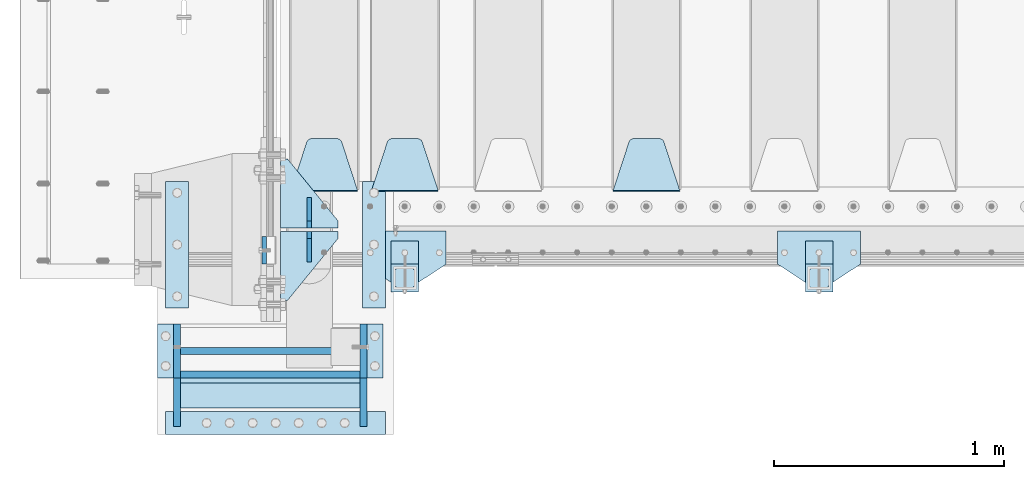
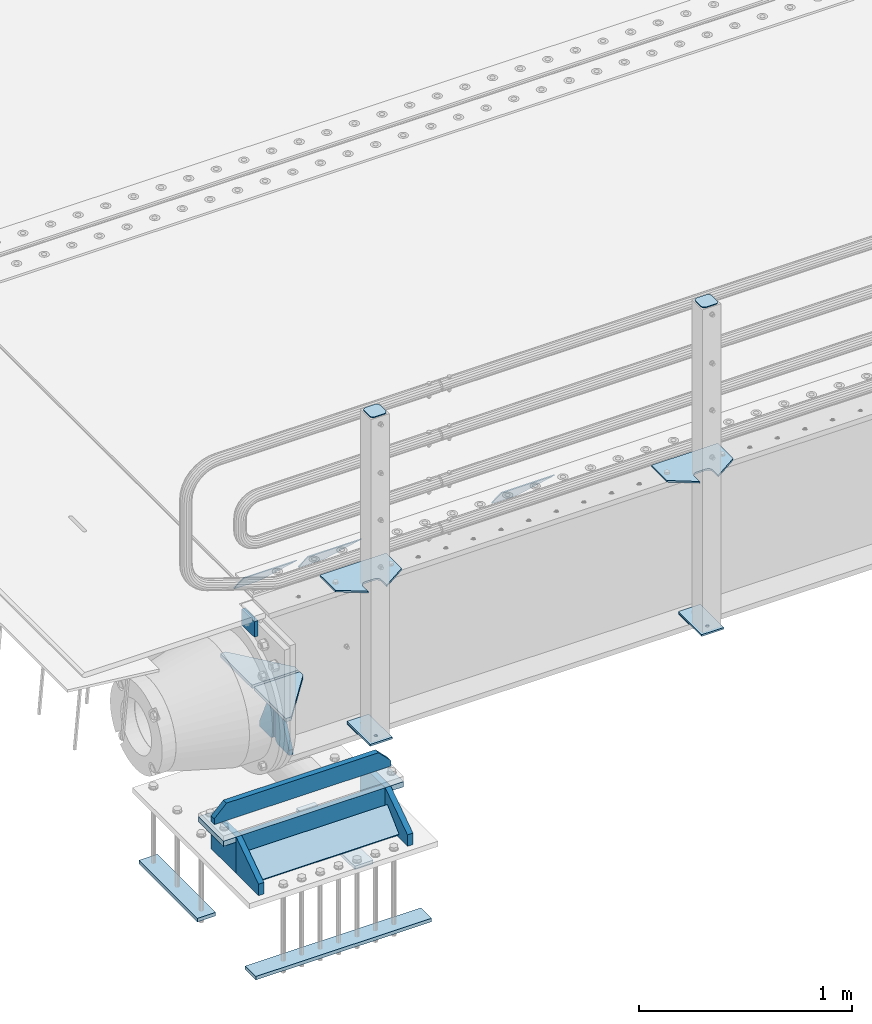
# One storey, part 202 of 257: 28 plates.
"""IFC2X3 building model written with IfcOpenShell, lengths in millimetres."""

from ifc_helpers import new_model, si_unit, frame, origin_with_axes, place, context, subcontext, project, spatial, faceted_brep, material, type_object, element, save


model = new_model("IFC2X3")

# Units and contexts
model_context = context("Model", 3, precision=1e-05, world=origin_with_axes())
body_context = subcontext(model_context, "Body", "Model", "MODEL_VIEW")
ifc_project = project(units=[si_unit("LENGTHUNIT", "METRE", prefix="MILLI"), si_unit("AREAUNIT", "SQUARE_METRE"), si_unit("VOLUMEUNIT", "CUBIC_METRE"), si_unit("MASSUNIT", "GRAM", prefix="KILO"), si_unit("TIMEUNIT", "SECOND"), si_unit("PLANEANGLEUNIT", "RADIAN"), si_unit("SOLIDANGLEUNIT", "STERADIAN"), si_unit("THERMODYNAMICTEMPERATUREUNIT", "DEGREE_CELSIUS"), si_unit("LUMINOUSINTENSITYUNIT", "LUMEN")], contexts=[model_context])

# Site, building, storey
site_placement = place(None, origin_with_axes())
site = spatial("IfcSite", under=ifc_project, at=site_placement, CompositionType="ELEMENT")
building_placement = place(site_placement, origin_with_axes())
building = spatial("IfcBuilding", under=site, at=building_placement, Name="Standard", CompositionType="ELEMENT")
storey_placement = place(building_placement, origin_with_axes())
storey = spatial("IfcBuildingStorey", under=building, at=storey_placement, Name="Undefined", CompositionType="ELEMENT", Elevation=0.0)

# Plates
ifc_material_1 = material(Name="STEEL/S355N")
plate_type_1 = type_object("IfcPlateType", PredefinedType="NOTDEFINED")
plate_1_placement = place(storey_placement, frame((42390.0, -29.9995540187374, -106.000123865875), z_axis=(0.0, -0.999999999987744, -4.95099999993769e-06), x_axis=(0.0, -4.95099999998473e-06, 0.999999999987744)))
element("IfcPlate", 1, at=plate_1_placement, inside=storey, type_object=plate_type_1, material=ifc_material_1, context=body_context, shape_type="Brep", body=[
    faceted_brep([(0.0, -10.0, 0.0), (5.7072624315424e-07, -10.0, 120.0), (5.7072624315424e-07, 10.0, 120.0), (0.0, 10.0, 0.0), (90.0, -10.0, 120.0), (90.0, 10.0, 120.0), (90.0, -10.0, 1.09139364212751e-11), (90.0, 10.0, 1.09139364212751e-11)], [[[0, 1, 2, 3]], [[1, 4, 5, 2]], [[4, 6, 7, 5]], [[6, 0, 3, 7]], [[5, 7, 3, 2]], [[6, 4, 1, 0]]]),
])
plate_type_2 = type_object("IfcPlateType", PredefinedType="NOTDEFINED")
plate_2_placement = place(storey_placement, frame((44195.0, 168.232233047034, -1.76776695296758), z_axis=(0.0, 0.707106781186547, -0.707106781186548), x_axis=(-1.0, 0.0, 0.0)))
element("IfcPlate", 2, at=plate_2_placement, inside=storey, type_object=plate_type_2, material=ifc_material_1, context=body_context, shape_type="Brep", body=[
    faceted_brep([(0.0, -2.5, 0.0), (69.345504679477, -2.50000000000091, 300.17173142483), (69.345504679477, 2.5, 300.171731424831), (0.0, 2.5, 0.0), (70.927406119954, -2.50000000000091, 304.8974424154), (70.927406119954, 2.5, 304.8974424154), (73.3818627772271, -2.50000000000091, 309.234538108527), (73.3818627772271, 2.49999999999909, 309.234538108527), (76.6187032999587, -2.5, 313.023683126103), (76.6187032999587, 2.5, 313.023683126103), (80.5190132705029, -2.5, 316.125672595372), (80.5190132705029, 2.5, 316.125672595371), (84.9395038596849, -2.5, 318.426546230476), (84.9395038596849, 2.5, 318.426546230477), (89.7177759439219, -2.5, 319.841774983275), (89.7177759439219, 2.5, 319.841774983275), (94.6782862926484, -2.5, 320.319366455079), (94.6782862926484, 2.5, 320.319366455079), (195.321713707352, -2.5, 320.319366455079), (195.321713707352, 2.5, 320.319366455079), (200.282224056078, -2.5, 319.841774983275), (200.282224056078, 2.49999999999909, 319.841774983275), (205.060496140315, -2.5, 318.426546230476), (205.060496140315, 2.49999999999909, 318.426546230475), (209.480986729497, -2.5, 316.125672595371), (209.480986729497, 2.5, 316.125672595371), (213.381296700041, -2.50000000000091, 313.023683126102), (213.381296700041, 2.5, 313.023683126103), (216.618137222766, -2.50000000000091, 309.234538108527), (216.618137222766, 2.5, 309.234538108527), (219.072593880039, -2.5, 304.897442415399), (219.072593880039, 2.5, 304.897442415399), (220.654495320523, -2.50000000000091, 300.17173142483), (220.654495320523, 2.5, 300.171731424831), (290.0, -2.50000000000091, 0.0), (290.0, 2.5, 9.09494701772928e-13)], [[[0, 1, 2, 3]], [[1, 4, 5, 2]], [[4, 6, 7, 5]], [[6, 8, 9, 7]], [[8, 10, 11, 9]], [[10, 12, 13, 11]], [[12, 14, 15, 13]], [[14, 16, 17, 15]], [[16, 18, 19, 17]], [[18, 20, 21, 19]], [[20, 22, 23, 21]], [[22, 24, 25, 23]], [[24, 26, 27, 25]], [[26, 28, 29, 27]], [[28, 30, 31, 29]], [[30, 32, 33, 31]], [[32, 34, 35, 33]], [[34, 0, 3, 35]], [[5, 7, 9, 11, 13, 15, 17, 19, 21, 23, 25, 27, 29, 31, 33, 35, 3, 2]], [[34, 32, 30, 28, 26, 24, 22, 20, 18, 16, 14, 12, 10, 8, 6, 4, 1, 0]]]),
])
plate_3_placement = place(storey_placement, frame((43145.0, 168.232233047034, -1.76776695296758), z_axis=(0.0, 0.707106781186547, -0.707106781186548), x_axis=(-1.0, 0.0, 0.0)))
element("IfcPlate", 3, at=plate_3_placement, inside=storey, type_object=plate_type_2, material=ifc_material_1, context=body_context, shape_type="Brep", body=[
    faceted_brep([(0.0, -2.5, 0.0), (69.345504679477, -2.50000000000091, 300.17173142483), (69.345504679477, 2.5, 300.171731424831), (0.0, 2.5, 0.0), (70.927406119954, -2.50000000000091, 304.8974424154), (70.927406119954, 2.5, 304.8974424154), (73.3818627772271, -2.50000000000091, 309.234538108527), (73.3818627772271, 2.49999999999909, 309.234538108527), (76.6187032999587, -2.5, 313.023683126103), (76.6187032999587, 2.5, 313.023683126103), (80.5190132705029, -2.5, 316.125672595372), (80.5190132705029, 2.5, 316.125672595371), (84.9395038596849, -2.5, 318.426546230476), (84.9395038596849, 2.5, 318.426546230477), (89.7177759439219, -2.5, 319.841774983275), (89.7177759439219, 2.5, 319.841774983275), (94.6782862926484, -2.5, 320.319366455079), (94.6782862926484, 2.5, 320.319366455079), (195.321713707352, -2.5, 320.319366455079), (195.321713707352, 2.5, 320.319366455079), (200.282224056078, -2.5, 319.841774983275), (200.282224056078, 2.49999999999909, 319.841774983275), (205.060496140315, -2.5, 318.426546230476), (205.060496140315, 2.49999999999909, 318.426546230475), (209.480986729497, -2.5, 316.125672595371), (209.480986729497, 2.5, 316.125672595371), (213.381296700041, -2.50000000000091, 313.023683126102), (213.381296700041, 2.5, 313.023683126103), (216.618137222766, -2.50000000000091, 309.234538108527), (216.618137222766, 2.5, 309.234538108527), (219.072593880039, -2.5, 304.897442415399), (219.072593880039, 2.5, 304.897442415399), (220.654495320523, -2.50000000000091, 300.17173142483), (220.654495320523, 2.5, 300.171731424831), (290.0, -2.50000000000091, 0.0), (290.0, 2.5, 9.09494701772928e-13)], [[[0, 1, 2, 3]], [[1, 4, 5, 2]], [[4, 6, 7, 5]], [[6, 8, 9, 7]], [[8, 10, 11, 9]], [[10, 12, 13, 11]], [[12, 14, 15, 13]], [[14, 16, 17, 15]], [[16, 18, 19, 17]], [[18, 20, 21, 19]], [[20, 22, 23, 21]], [[22, 24, 25, 23]], [[24, 26, 27, 25]], [[26, 28, 29, 27]], [[28, 30, 31, 29]], [[30, 32, 33, 31]], [[32, 34, 35, 33]], [[34, 0, 3, 35]], [[5, 7, 9, 11, 13, 15, 17, 19, 21, 23, 25, 27, 29, 31, 33, 35, 3, 2]], [[34, 32, 30, 28, 26, 24, 22, 20, 18, 16, 14, 12, 10, 8, 6, 4, 1, 0]]]),
])
plate_4_placement = place(storey_placement, frame((42795.0, 168.232233047034, -1.76776695296758), z_axis=(0.0, 0.707106781186547, -0.707106781186548), x_axis=(-1.0, 0.0, 0.0)))
element("IfcPlate", 4, at=plate_4_placement, inside=storey, type_object=plate_type_2, material=ifc_material_1, context=body_context, shape_type="Brep", body=[
    faceted_brep([(0.0, -2.5, 0.0), (69.345504679477, -2.50000000000091, 300.17173142483), (69.345504679477, 2.5, 300.171731424831), (0.0, 2.5, 0.0), (70.927406119954, -2.50000000000091, 304.8974424154), (70.927406119954, 2.5, 304.8974424154), (73.3818627772271, -2.50000000000091, 309.234538108527), (73.3818627772271, 2.49999999999909, 309.234538108527), (76.6187032999587, -2.5, 313.023683126103), (76.6187032999587, 2.5, 313.023683126103), (80.5190132705029, -2.5, 316.125672595372), (80.5190132705029, 2.5, 316.125672595371), (84.9395038596849, -2.5, 318.426546230476), (84.9395038596849, 2.5, 318.426546230477), (89.7177759439219, -2.5, 319.841774983275), (89.7177759439219, 2.5, 319.841774983275), (94.6782862926484, -2.5, 320.319366455079), (94.6782862926484, 2.5, 320.319366455079), (195.321713707352, -2.5, 320.319366455079), (195.321713707352, 2.5, 320.319366455079), (200.282224056078, -2.5, 319.841774983275), (200.282224056078, 2.49999999999909, 319.841774983275), (205.060496140315, -2.5, 318.426546230476), (205.060496140315, 2.49999999999909, 318.426546230475), (209.480986729497, -2.5, 316.125672595371), (209.480986729497, 2.5, 316.125672595371), (213.381296700041, -2.50000000000091, 313.023683126102), (213.381296700041, 2.5, 313.023683126103), (216.618137222766, -2.50000000000091, 309.234538108527), (216.618137222766, 2.5, 309.234538108527), (219.072593880039, -2.5, 304.897442415399), (219.072593880039, 2.5, 304.897442415399), (220.654495320523, -2.50000000000091, 300.17173142483), (220.654495320523, 2.5, 300.171731424831), (290.0, -2.50000000000091, 0.0), (290.0, 2.5, 9.09494701772928e-13)], [[[0, 1, 2, 3]], [[1, 4, 5, 2]], [[4, 6, 7, 5]], [[6, 8, 9, 7]], [[8, 10, 11, 9]], [[10, 12, 13, 11]], [[12, 14, 15, 13]], [[14, 16, 17, 15]], [[16, 18, 19, 17]], [[18, 20, 21, 19]], [[20, 22, 23, 21]], [[22, 24, 25, 23]], [[24, 26, 27, 25]], [[26, 28, 29, 27]], [[28, 30, 31, 29]], [[30, 32, 33, 31]], [[32, 34, 35, 33]], [[34, 0, 3, 35]], [[5, 7, 9, 11, 13, 15, 17, 19, 21, 23, 25, 27, 29, 31, 33, 35, 3, 2]], [[34, 32, 30, 28, 26, 24, 22, 20, 18, 16, 14, 12, 10, 8, 6, 4, 1, 0]]]),
])
plate_type_3 = type_object("IfcPlateType", PredefinedType="NOTDEFINED")
for number, where, z_axis, x_axis in (
    (5, (42710.0, 8.0, -515.0), (0.0, 1.0, 0.0), (-1.0, 0.0, 0.0)),
    (6, (42710.0, -8.0, -515.0), (0.0, -1.0, 0.0), (-1.0, 0.0, 0.0)),
):
    element("IfcPlate", number, at=place(storey_placement, frame(where, z_axis=z_axis, x_axis=x_axis)), inside=storey, type_object=plate_type_3, material=ifc_material_1, context=body_context, shape_type="Brep", body=[
        faceted_brep([(0.0, -10.0, 0.0), (0.0, -10.0, 30.0), (0.0, 10.0, 30.0), (0.0, 10.0, 0.0), (220.0, -10.0, 300.0), (220.0, 10.0, 300.0), (250.0, -10.0, 300.0), (250.0, 10.0, 300.0), (250.0, -10.0, 0.0), (250.0, 10.0, 0.0)], [[[0, 1, 2, 3]], [[1, 4, 5, 2]], [[4, 6, 7, 5]], [[6, 8, 9, 7]], [[8, 0, 3, 9]], [[5, 7, 9, 3, 2]], [[8, 6, 4, 1, 0]]]),
    ])
plate_type_4 = type_object("IfcPlateType", PredefinedType="NOTDEFINED")
for number, where, z_axis, x_axis in (
    (7, (42585.0, 140.0, -860.0), (0.0, 0.0, 1.0), (0.0, -1.0, 0.0)),
    (8, (42585.0, -140.0, -860.0), (0.0, 0.0, 1.0), (0.0, 1.0, 0.0)),
):
    element("IfcPlate", number, at=place(storey_placement, frame(where, z_axis=z_axis, x_axis=x_axis)), inside=storey, type_object=plate_type_4, material=ifc_material_1, context=body_context, shape_type="Brep", body=[
        faceted_brep([(0.0, -10.0, 0.0), (0.0, -10.0, 30.0), (0.0, 10.0, 30.0), (0.0, 10.0, 0.0), (102.0, -10.0, 250.0), (102.0, 10.0, 250.0), (132.0, -10.0, 250.0), (132.0, 10.0, 250.0), (132.0, -10.0, 30.0), (132.0, 10.0, 30.0), (131.544232590366, -10.0, 24.790554669992), (131.544232590366, 10.0, 24.790554669992), (130.190778623577, -10.0, 19.7393957002299), (130.190778623577, 10.0, 19.7393957002299), (127.980762113533, -10.0, 15.0), (127.980762113533, 10.0, 15.0), (124.981333293569, -10.0, 10.7163717094038), (124.981333293569, 10.0, 10.7163717094038), (121.283628290596, -10.0, 7.01866670643062), (121.283628290596, 10.0, 7.01866670643062), (117.0, -10.0, 4.01923788646684), (117.0, 10.0, 4.01923788646684), (112.26060429977, -10.0, 1.80922137642278), (112.26060429977, 10.0, 1.80922137642278), (107.209445330008, -10.0, 0.455767409633722), (107.209445330008, 10.0, 0.455767409633722), (102.0, -10.0, 0.0), (102.0, 10.0, 0.0)], [[[0, 1, 2, 3]], [[1, 4, 5, 2]], [[4, 6, 7, 5]], [[6, 8, 9, 7]], [[8, 10, 11, 9]], [[10, 12, 13, 11]], [[12, 14, 15, 13]], [[14, 16, 17, 15]], [[16, 18, 19, 17]], [[18, 20, 21, 19]], [[20, 22, 23, 21]], [[22, 24, 25, 23]], [[24, 26, 27, 25]], [[26, 0, 3, 27]], [[5, 7, 9, 11, 13, 15, 17, 19, 21, 23, 25, 27, 3, 2]], [[26, 24, 22, 20, 18, 16, 14, 12, 10, 8, 6, 4, 1, 0]]]),
    ])
ifc_material_2 = material(Name="STEEL/S355J2")
plate_type_5 = type_object("IfcPlateType", PredefinedType="NOTDEFINED")
plate_5_placement = place(storey_placement, frame((44980.0, -4.99999999999636, 5.00000000004911), z_axis=(0.0, -1.0, 0.0), x_axis=(-1.0, 0.0, 0.0)))
element("IfcPlate", 9, at=plate_5_placement, inside=storey, type_object=plate_type_5, material=ifc_material_2, context=body_context, shape_type="Brep", body=[
    faceted_brep([(0.0, -5.0, 0.0), (2.31396552408114e-06, -5.0, 145.0), (2.31396552408114e-06, 5.0, 145.0), (0.0, 5.0, 0.0), (130.0, -5.0, 230.0), (130.0, 5.0, 230.0), (130.0, -5.0, 180.0), (130.0, 5.0, 180.0), (130.48036798992, -5.0, 175.122741949597), (130.48036798992, 5.0, 175.122741949597), (131.903011687216, -5.0, 170.432914190873), (131.903011687216, 5.0, 170.432914190873), (134.213259692435, -5.0, 166.11074417451), (134.213259692435, 5.0, 166.11074417451), (137.322330470335, -5.0, 162.322330470337), (137.322330470335, 5.0, 162.322330470337), (141.110744174512, -5.0, 159.213259692437), (141.110744174512, 5.0, 159.213259692437), (145.432914190875, -5.0, 156.903011687218), (145.432914190875, 5.0, 156.903011687218), (150.122741949599, -5.0, 155.48036798992), (150.122741949599, 5.0, 155.48036798992), (155.0, -5.0, 155.0), (155.0, 5.0, 155.0), (205.0, -5.0, 155.0), (205.0, 5.0, 155.0), (209.877258050401, -5.0, 155.48036798992), (209.877258050401, 5.0, 155.48036798992), (214.567085809125, -5.0, 156.903011687218), (214.567085809125, 5.0, 156.903011687218), (218.889255825488, -5.0, 159.213259692437), (218.889255825488, 5.0, 159.213259692437), (222.677669529665, -5.0, 162.322330470337), (222.677669529665, 5.0, 162.322330470337), (225.786740307565, -5.0, 166.11074417451), (225.786740307565, 5.0, 166.11074417451), (228.096988312784, -5.0, 170.432914190873), (228.096988312784, 5.0, 170.432914190873), (229.51963201008, -5.0, 175.122741949597), (229.51963201008, 5.0, 175.122741949597), (230.0, -5.0, 180.0), (230.0, 5.0, 180.0), (230.0, -5.0, 230.0), (230.0, 5.0, 230.0), (360.0, -5.0, 145.0), (360.0, 5.0, 145.0), (360.0, -5.0, -7.27595761418343e-12), (360.0, 5.0, -7.27595761418343e-12)], [[[0, 1, 2, 3]], [[1, 4, 5, 2]], [[4, 6, 7, 5]], [[6, 8, 9, 7]], [[8, 10, 11, 9]], [[10, 12, 13, 11]], [[12, 14, 15, 13]], [[14, 16, 17, 15]], [[16, 18, 19, 17]], [[18, 20, 21, 19]], [[20, 22, 23, 21]], [[22, 24, 25, 23]], [[24, 26, 27, 25]], [[26, 28, 29, 27]], [[28, 30, 31, 29]], [[30, 32, 33, 31]], [[32, 34, 35, 33]], [[34, 36, 37, 35]], [[36, 38, 39, 37]], [[38, 40, 41, 39]], [[40, 42, 43, 41]], [[42, 44, 45, 43]], [[44, 46, 47, 45]], [[46, 0, 3, 47]], [[5, 7, 9, 11, 13, 15, 17, 19, 21, 23, 25, 27, 29, 31, 33, 35, 37, 39, 41, 43, 45, 47, 3, 2]], [[46, 44, 42, 40, 38, 36, 34, 32, 30, 28, 26, 24, 22, 20, 18, 16, 14, 12, 10, 8, 6, 4, 1, 0]]]),
])
plate_6_placement = place(storey_placement, frame((43180.0, -4.99999999999636, 5.00000000004911), z_axis=(0.0, -1.0, 0.0), x_axis=(-1.0, 0.0, 0.0)))
element("IfcPlate", 10, at=plate_6_placement, inside=storey, type_object=plate_type_5, material=ifc_material_2, context=body_context, shape_type="Brep", body=[
    faceted_brep([(0.0, -5.0, 0.0), (2.31396552408114e-06, -5.0, 145.0), (2.31396552408114e-06, 5.0, 145.0), (0.0, 5.0, 0.0), (130.0, -5.0, 230.0), (130.0, 5.0, 230.0), (130.0, -5.0, 180.0), (130.0, 5.0, 180.0), (130.48036798992, -5.0, 175.122741949597), (130.48036798992, 5.0, 175.122741949597), (131.903011687216, -5.0, 170.432914190873), (131.903011687216, 5.0, 170.432914190873), (134.213259692435, -5.0, 166.11074417451), (134.213259692435, 5.0, 166.11074417451), (137.322330470335, -5.0, 162.322330470337), (137.322330470335, 5.0, 162.322330470337), (141.110744174512, -5.0, 159.213259692437), (141.110744174512, 5.0, 159.213259692437), (145.432914190875, -5.0, 156.903011687218), (145.432914190875, 5.0, 156.903011687218), (150.122741949599, -5.0, 155.48036798992), (150.122741949599, 5.0, 155.48036798992), (155.0, -5.0, 155.0), (155.0, 5.0, 155.0), (205.0, -5.0, 155.0), (205.0, 5.0, 155.0), (209.877258050401, -5.0, 155.48036798992), (209.877258050401, 5.0, 155.48036798992), (214.567085809125, -5.0, 156.903011687218), (214.567085809125, 5.0, 156.903011687218), (218.889255825488, -5.0, 159.213259692437), (218.889255825488, 5.0, 159.213259692437), (222.677669529665, -5.0, 162.322330470337), (222.677669529665, 5.0, 162.322330470337), (225.786740307565, -5.0, 166.11074417451), (225.786740307565, 5.0, 166.11074417451), (228.096988312784, -5.0, 170.432914190873), (228.096988312784, 5.0, 170.432914190873), (229.51963201008, -5.0, 175.122741949597), (229.51963201008, 5.0, 175.122741949597), (230.0, -5.0, 180.0), (230.0, 5.0, 180.0), (230.0, -5.0, 230.0), (230.0, 5.0, 230.0), (360.0, -5.0, 145.0), (360.0, 5.0, 145.0), (360.0, -5.0, -7.27595761418343e-12), (360.0, 5.0, -7.27595761418343e-12)], [[[0, 1, 2, 3]], [[1, 4, 5, 2]], [[4, 6, 7, 5]], [[6, 8, 9, 7]], [[8, 10, 11, 9]], [[10, 12, 13, 11]], [[12, 14, 15, 13]], [[14, 16, 17, 15]], [[16, 18, 19, 17]], [[18, 20, 21, 19]], [[20, 22, 23, 21]], [[22, 24, 25, 23]], [[24, 26, 27, 25]], [[26, 28, 29, 27]], [[28, 30, 31, 29]], [[30, 32, 33, 31]], [[32, 34, 35, 33]], [[34, 36, 37, 35]], [[36, 38, 39, 37]], [[38, 40, 41, 39]], [[40, 42, 43, 41]], [[42, 44, 45, 43]], [[44, 46, 47, 45]], [[46, 0, 3, 47]], [[5, 7, 9, 11, 13, 15, 17, 19, 21, 23, 25, 27, 29, 31, 33, 35, 37, 39, 41, 43, 45, 47, 3, 2]], [[46, 44, 42, 40, 38, 36, 34, 32, 30, 28, 26, 24, 22, 20, 18, 16, 14, 12, 10, 8, 6, 4, 1, 0]]]),
])
plate_type_6 = type_object("IfcPlateType", PredefinedType="NOTDEFINED")
for number, where, z_axis, x_axis in (
    (11, (44859.9999999999, -50.0000000002074, -850.000000000002), (0.0, -1.0, 0.0), (-1.0, 0.0, 0.0)),
    (12, (43059.9999999999, -50.0000000002074, -850.000000000002), (0.0, -1.0, 0.0), (-1.0, 0.0, 0.0)),
):
    element("IfcPlate", number, at=place(storey_placement, frame(where, z_axis=z_axis, x_axis=x_axis)), inside=storey, type_object=plate_type_6, material=ifc_material_2, context=body_context, shape_type="Brep", body=[
        faceted_brep([(53.6360389691836, -5.0, 176.363961030469), (53.6360389691836, 5.0, 176.363961030469), (59.9999999998618, 5.0, 178.999999999791), (59.9999999998618, -5.0, 178.999999999791), (66.3639610305399, 5.0, 176.363961030469), (66.3639610305399, -5.0, 176.363961030469), (68.9999999998618, 5.0, 169.999999999791), (68.9999999998618, -5.0, 169.999999999791), (66.3639610305399, 5.0, 163.636038969113), (66.3639610305399, -5.0, 163.636038969113), (59.9999999998618, 5.0, 160.999999999791), (59.9999999998618, -5.0, 160.999999999791), (53.6360389691836, 5.0, 163.636038969113), (53.6360389691836, -5.0, 163.636038969113), (50.9999999998618, 5.0, 169.999999999791), (50.9999999998618, -5.0, 169.999999999791), (120.0, -5.0, 0.0), (120.0, -5.0, 220.0), (0.0, -5.0, 220.0), (0.0, -5.0, 0.0), (0.0, 5.0, 0.0), (120.0, 5.0, 0.0), (120.0, 5.0, 220.0), (0.0, 5.0, 220.0)], [[[0, 1, 2, 3]], [[3, 2, 4, 5]], [[5, 4, 6, 7]], [[7, 6, 8, 9]], [[9, 8, 10, 11]], [[11, 10, 12, 13]], [[13, 12, 14, 15]], [[15, 14, 1, 0]], [[16, 17, 18, 19], [11, 13, 15, 0, 3, 5, 7, 9]], [[16, 19, 20, 21]], [[17, 16, 21, 22]], [[18, 17, 22, 23]], [[19, 18, 23, 20]], [[22, 21, 20, 23], [2, 1, 14, 12, 10, 8, 6, 4]]]),
    ])
plate_type_7 = type_object("IfcPlateType", PredefinedType="NOTDEFINED")
plate_7_placement = place(storey_placement, frame((44755.9999999999, -166.000000000207, 1012.50000000001), z_axis=(0.0, -1.0, 0.0), x_axis=(1.0, 0.0, 0.0)))
element("IfcPlate", 13, at=plate_7_placement, inside=storey, type_object=plate_type_7, material=ifc_material_2, context=body_context, shape_type="Brep", body=[
    faceted_brep([(0.0, -2.5, 19.0), (0.0, -2.5, 69.0), (0.0, 2.5, 69.0), (0.0, 2.5, 19.0), (0.476369668547704, -2.5, 73.2278977451697), (0.476369668547704, 2.5, 73.2278977451697), (1.88159150985302, -2.5, 77.2437910432327), (1.88159150985302, 2.5, 77.2437910432327), (4.14520183311106, -2.5, 80.8463062353167), (4.14520183311106, 2.5, 80.8463062353167), (7.15369376468152, -2.5, 83.8547981668926), (7.15369376468152, 2.5, 83.8547981668926), (10.7562089567655, -2.5, 86.1184084901452), (10.7562089567655, 2.5, 86.1184084901452), (14.7721022548285, -2.5, 87.5236303314541), (14.7721022548285, 2.5, 87.5236303314541), (19.0, -2.5, 88.0), (19.0, 2.5, 88.0), (69.0, -2.5, 88.0), (69.0, 2.5, 88.0), (73.2278977451715, -2.5, 87.5236303314541), (73.2278977451715, 2.5, 87.5236303314541), (77.2437910432345, -2.5, 86.1184084901452), (77.2437910432345, 2.5, 86.1184084901452), (80.8463062353185, -2.5, 83.8547981668926), (80.8463062353185, 2.5, 83.8547981668926), (83.8547981668889, -2.5, 80.8463062353167), (83.8547981668889, 2.5, 80.8463062353167), (86.118408490147, -2.5, 77.2437910432327), (86.118408490147, 2.5, 77.2437910432327), (87.5236303314523, -2.5, 73.2278977451697), (87.5236303314523, 2.5, 73.2278977451697), (88.0, -2.5, 69.0), (88.0, 2.5, 69.0), (88.0, -2.5, 19.0), (88.0, 2.5, 19.0), (87.5236303314523, -2.5, 14.7721022548303), (87.5236303314523, 2.5, 14.7721022548303), (86.118408490147, -2.5, 10.7562089567673), (86.118408490147, 2.5, 10.7562089567673), (83.8547981668889, -2.5, 7.15369376468334), (83.8547981668889, 2.5, 7.15369376468334), (80.8463062353185, -2.5, 4.14520183310742), (80.8463062353185, 2.5, 4.14520183310742), (77.2437910432345, -2.5, 1.88159150985484), (77.2437910432345, 2.5, 1.88159150985484), (73.2278977451715, -2.5, 0.476369668545885), (73.2278977451715, 2.5, 0.476369668545885), (69.0, -2.5, 0.0), (69.0, 2.5, 0.0), (19.0, -2.5, 0.0), (19.0, 2.5, 0.0), (14.7721022548285, -2.5, 0.476369668545885), (14.7721022548285, 2.5, 0.476369668545885), (10.7562089567655, -2.5, 1.88159150985484), (10.7562089567655, 2.5, 1.88159150985484), (7.15369376468152, -2.5, 4.14520183310742), (7.15369376468152, 2.5, 4.14520183310742), (4.14520183311106, -2.5, 7.15369376468334), (4.14520183311106, 2.5, 7.15369376468334), (1.88159150985302, -2.5, 10.7562089567673), (1.88159150985302, 2.5, 10.7562089567673), (0.476369668547704, -2.5, 14.7721022548303), (0.476369668547704, 2.5, 14.7721022548303)], [[[0, 1, 2, 3]], [[1, 4, 5, 2]], [[4, 6, 7, 5]], [[6, 8, 9, 7]], [[8, 10, 11, 9]], [[10, 12, 13, 11]], [[12, 14, 15, 13]], [[14, 16, 17, 15]], [[16, 18, 19, 17]], [[18, 20, 21, 19]], [[20, 22, 23, 21]], [[22, 24, 25, 23]], [[24, 26, 27, 25]], [[26, 28, 29, 27]], [[28, 30, 31, 29]], [[30, 32, 33, 31]], [[32, 34, 35, 33]], [[34, 36, 37, 35]], [[36, 38, 39, 37]], [[38, 40, 41, 39]], [[40, 42, 43, 41]], [[42, 44, 45, 43]], [[44, 46, 47, 45]], [[46, 48, 49, 47]], [[48, 50, 51, 49]], [[50, 52, 53, 51]], [[52, 54, 55, 53]], [[54, 56, 57, 55]], [[56, 58, 59, 57]], [[58, 60, 61, 59]], [[60, 62, 63, 61]], [[62, 0, 3, 63]], [[5, 7, 9, 11, 13, 15, 17, 19, 21, 23, 25, 27, 29, 31, 33, 35, 37, 39, 41, 43, 45, 47, 49, 51, 53, 55, 57, 59, 61, 63, 3, 2]], [[62, 60, 58, 56, 54, 52, 50, 48, 46, 44, 42, 40, 38, 36, 34, 32, 30, 28, 26, 24, 22, 20, 18, 16, 14, 12, 10, 8, 6, 4, 1, 0]]]),
])
plate_8_placement = place(storey_placement, frame((42955.9999999999, -166.000000000207, 1012.50000000001), z_axis=(0.0, -1.0, 0.0), x_axis=(1.0, 0.0, 0.0)))
element("IfcPlate", 14, at=plate_8_placement, inside=storey, type_object=plate_type_7, material=ifc_material_2, context=body_context, shape_type="Brep", body=[
    faceted_brep([(0.0, -2.5, 19.0), (0.0, -2.5, 69.0), (0.0, 2.5, 69.0), (0.0, 2.5, 19.0), (0.476369668547704, -2.5, 73.2278977451697), (0.476369668547704, 2.5, 73.2278977451697), (1.88159150985302, -2.5, 77.2437910432327), (1.88159150985302, 2.5, 77.2437910432327), (4.14520183311106, -2.5, 80.8463062353167), (4.14520183311106, 2.5, 80.8463062353167), (7.15369376468152, -2.5, 83.8547981668926), (7.15369376468152, 2.5, 83.8547981668926), (10.7562089567655, -2.5, 86.1184084901452), (10.7562089567655, 2.5, 86.1184084901452), (14.7721022548285, -2.5, 87.5236303314541), (14.7721022548285, 2.5, 87.5236303314541), (19.0, -2.5, 88.0), (19.0, 2.5, 88.0), (69.0, -2.5, 88.0), (69.0, 2.5, 88.0), (73.2278977451715, -2.5, 87.5236303314541), (73.2278977451715, 2.5, 87.5236303314541), (77.2437910432345, -2.5, 86.1184084901452), (77.2437910432345, 2.5, 86.1184084901452), (80.8463062353185, -2.5, 83.8547981668926), (80.8463062353185, 2.5, 83.8547981668926), (83.8547981668889, -2.5, 80.8463062353167), (83.8547981668889, 2.5, 80.8463062353167), (86.118408490147, -2.5, 77.2437910432327), (86.118408490147, 2.5, 77.2437910432327), (87.5236303314523, -2.5, 73.2278977451697), (87.5236303314523, 2.5, 73.2278977451697), (88.0, -2.5, 69.0), (88.0, 2.5, 69.0), (88.0, -2.5, 19.0), (88.0, 2.5, 19.0), (87.5236303314523, -2.5, 14.7721022548303), (87.5236303314523, 2.5, 14.7721022548303), (86.118408490147, -2.5, 10.7562089567673), (86.118408490147, 2.5, 10.7562089567673), (83.8547981668889, -2.5, 7.15369376468334), (83.8547981668889, 2.5, 7.15369376468334), (80.8463062353185, -2.5, 4.14520183310742), (80.8463062353185, 2.5, 4.14520183310742), (77.2437910432345, -2.5, 1.88159150985484), (77.2437910432345, 2.5, 1.88159150985484), (73.2278977451715, -2.5, 0.476369668545885), (73.2278977451715, 2.5, 0.476369668545885), (69.0, -2.5, 0.0), (69.0, 2.5, 0.0), (19.0, -2.5, 0.0), (19.0, 2.5, 0.0), (14.7721022548285, -2.5, 0.476369668545885), (14.7721022548285, 2.5, 0.476369668545885), (10.7562089567655, -2.5, 1.88159150985484), (10.7562089567655, 2.5, 1.88159150985484), (7.15369376468152, -2.5, 4.14520183310742), (7.15369376468152, 2.5, 4.14520183310742), (4.14520183311106, -2.5, 7.15369376468334), (4.14520183311106, 2.5, 7.15369376468334), (1.88159150985302, -2.5, 10.7562089567673), (1.88159150985302, 2.5, 10.7562089567673), (0.476369668547704, -2.5, 14.7721022548303), (0.476369668547704, 2.5, 14.7721022548303)], [[[0, 1, 2, 3]], [[1, 4, 5, 2]], [[4, 6, 7, 5]], [[6, 8, 9, 7]], [[8, 10, 11, 9]], [[10, 12, 13, 11]], [[12, 14, 15, 13]], [[14, 16, 17, 15]], [[16, 18, 19, 17]], [[18, 20, 21, 19]], [[20, 22, 23, 21]], [[22, 24, 25, 23]], [[24, 26, 27, 25]], [[26, 28, 29, 27]], [[28, 30, 31, 29]], [[30, 32, 33, 31]], [[32, 34, 35, 33]], [[34, 36, 37, 35]], [[36, 38, 39, 37]], [[38, 40, 41, 39]], [[40, 42, 43, 41]], [[42, 44, 45, 43]], [[44, 46, 47, 45]], [[46, 48, 49, 47]], [[48, 50, 51, 49]], [[50, 52, 53, 51]], [[52, 54, 55, 53]], [[54, 56, 57, 55]], [[56, 58, 59, 57]], [[58, 60, 61, 59]], [[60, 62, 63, 61]], [[62, 0, 3, 63]], [[5, 7, 9, 11, 13, 15, 17, 19, 21, 23, 25, 27, 29, 31, 33, 35, 37, 39, 41, 43, 45, 47, 49, 51, 53, 55, 57, 59, 61, 63, 3, 2]], [[62, 60, 58, 56, 54, 52, 50, 48, 46, 44, 42, 40, 38, 36, 34, 32, 30, 28, 26, 24, 22, 20, 18, 16, 14, 12, 10, 8, 6, 4, 1, 0]]]),
])
plate_type_8 = type_object("IfcPlateType", PredefinedType="NOTDEFINED")
for number, where, z_axis, x_axis in (
    (15, (44859.9999999999, -50.0000000002074, -857.500000000002), (0.0, -1.0, 0.0), (-1.0, 0.0, 0.0)),
    (16, (43059.9999999999, -50.0000000002074, -857.500000000002), (0.0, -1.0, 0.0), (-1.0, 0.0, 0.0)),
):
    element("IfcPlate", number, at=place(storey_placement, frame(where, z_axis=z_axis, x_axis=x_axis)), inside=storey, type_object=plate_type_8, material=ifc_material_2, context=body_context, shape_type="Brep", body=[
        faceted_brep([(0.0, -2.5, 0.0), (0.0, -2.5, 100.0), (0.0, 2.5, 100.0), (0.0, 2.5, 0.0), (120.0, -2.5, 100.0), (120.0, 2.5, 100.0), (120.0, -2.5, 0.0), (120.0, 2.5, 0.0)], [[[0, 1, 2, 3]], [[1, 4, 5, 2]], [[4, 6, 7, 5]], [[6, 0, 3, 7]], [[5, 7, 3, 2]], [[6, 4, 1, 0]]]),
    ])
plate_type_9 = type_object("IfcPlateType", PredefinedType="NOTDEFINED")
plate_9_placement = place(storey_placement, frame((42805.0, -765.357134753237, -1017.14966545662), z_axis=(-1.0, 0.0, 0.0), x_axis=(0.0, 0.723355636225728, 0.690475650215467)))
element("IfcPlate", 17, at=plate_9_placement, inside=storey, type_object=plate_type_9, material=ifc_material_1, context=body_context, shape_type="Brep", body=[
    faceted_brep([(0.0, -15.0, 0.0), (3.63797880709171e-12, -15.0, 779.0), (1.81898940354586e-12, 15.0000000000009, 779.0), (0.0, 15.0, 0.0), (152.069061279299, -14.9999999999991, 779.0), (152.069061279301, 14.9999999999991, 779.0), (152.069061279299, -14.9999999999991, 0.0), (152.069061279301, 14.9999999999991, 0.0)], [[[0, 1, 2, 3]], [[1, 4, 5, 2]], [[4, 6, 7, 5]], [[6, 0, 3, 7]], [[5, 7, 3, 2]], [[6, 4, 1, 0]]]),
])
plate_type_10 = type_object("IfcPlateType", PredefinedType="NOTDEFINED")
for number, where, z_axis, x_axis in (
    (18, (42816.0, -339.999998533764, -1468.0), (0.0, 1.0, 0.0), (1.0, 0.0, 0.0)),
    (19, (41961.0, -339.999998533764, -1468.0), (0.0, 1.0, 0.0), (1.0, 0.0, 0.0)),
):
    element("IfcPlate", number, at=place(storey_placement, frame(where, z_axis=z_axis, x_axis=x_axis)), inside=storey, type_object=plate_type_10, material=ifc_material_1, context=body_context, shape_type="Brep", body=[
        faceted_brep([(0.0, -10.0, 0.0), (1.00942997960374e-06, -10.0, 550.0), (1.00942997960374e-06, 10.0, 550.0), (0.0, 10.0, 0.0), (100.0, -10.0, 550.0), (100.0, 10.0, 550.0), (100.0, -10.0, 0.0), (100.0, 10.0, 0.0)], [[[0, 1, 2, 3]], [[1, 4, 5, 2]], [[4, 6, 7, 5]], [[6, 0, 3, 7]], [[5, 7, 3, 2]], [[6, 4, 1, 0]]]),
    ])
plate_10_placement = place(storey_placement, frame((41961.0, -889.999998533764, -1468.0), z_axis=(0.0, 1.0, 0.0), x_axis=(1.0, 0.0, 0.0)))
element("IfcPlate", 20, at=plate_10_placement, inside=storey, type_object=plate_type_10, material=ifc_material_1, context=body_context, shape_type="Brep", body=[
    faceted_brep([(0.0, -10.0, 0.0), (0.0, -10.0, 100.0), (0.0, 10.0, 100.0), (0.0, 10.0, 0.0), (955.0, -10.0, 100.0), (955.0, 10.0, 100.0), (955.0, -10.0, 0.0), (955.0, 10.0, 0.0)], [[[0, 1, 2, 3]], [[1, 4, 5, 2]], [[4, 6, 7, 5]], [[6, 0, 3, 7]], [[5, 7, 3, 2]], [[6, 4, 1, 0]]]),
])
plate_type_11 = type_object("IfcPlateType", PredefinedType="NOTDEFINED")
plate_11_placement = place(storey_placement, frame((42820.0, -410.0, -818.000000000005), z_axis=(0.0, 0.0, -1.0), x_axis=(0.0, -1.0, 0.0)))
element("IfcPlate", 21, at=plate_11_placement, inside=storey, type_object=plate_type_11, material=ifc_material_1, context=body_context, shape_type="Brep", body=[
    faceted_brep([(0.0, -15.0, 0.0), (0.0, -15.0, 210.0), (0.0, 15.0, 210.0), (0.0, 15.0, 0.0), (235.0, -15.0, 210.0), (235.0, 15.0, 210.0), (235.0, -15.0, 0.0), (235.0, 15.0, 0.0)], [[[0, 1, 2, 3]], [[1, 4, 5, 2]], [[4, 6, 7, 5]], [[6, 0, 3, 7]], [[5, 7, 3, 2]], [[6, 4, 1, 0]]]),
])
for number, where, z_axis, x_axis in (
    (22, (42820.0, -855.0, -1028.0), (0.0, 0.0, 1.0), (0.0, 1.0, 0.0)),
    (23, (42011.0, -855.0, -1028.0), (0.0, 0.0, 1.0), (0.0, 1.0, 0.0)),
):
    element("IfcPlate", number, at=place(storey_placement, frame(where, z_axis=z_axis, x_axis=x_axis)), inside=storey, type_object=plate_type_11, material=ifc_material_1, context=body_context, shape_type="Brep", body=[
        faceted_brep([(0.0, -15.0, 0.0), (0.0, -15.0, 66.0), (0.0, 15.0, 66.0), (0.0, 15.0, 0.0), (210.0, -15.0, 210.0), (210.0, 15.0, 210.0), (210.0, -15.0, 0.0), (210.0, 15.0, 0.0)], [[[0, 1, 2, 3]], [[1, 4, 5, 2]], [[4, 6, 7, 5]], [[6, 0, 3, 7]], [[5, 7, 3, 2]], [[6, 4, 1, 0]]]),
    ])
plate_12_placement = place(storey_placement, frame((42026.0, -630.0, -1028.0), z_axis=(1.0, 0.0, 0.0), x_axis=(0.0, 0.0, 1.0)))
element("IfcPlate", 24, at=plate_12_placement, inside=storey, type_object=plate_type_11, material=ifc_material_1, context=body_context, shape_type="Brep", body=[
    faceted_brep([(0.0, -15.0, 0.0), (3.63797880709171e-12, -15.0, 779.0), (1.81898940354586e-12, 15.0000000000009, 779.0), (0.0, 15.0, 0.0), (210.0, -15.0, 779.0), (210.0, 15.0, 779.0), (210.0, -15.0, 0.0), (210.0, 15.0, 0.0)], [[[0, 1, 2, 3]], [[1, 4, 5, 2]], [[4, 6, 7, 5]], [[6, 0, 3, 7]], [[5, 7, 3, 2]], [[6, 4, 1, 0]]]),
])
plate_13_placement = place(storey_placement, frame((42011.0, -410.0, -818.000000000004), z_axis=(0.0, 0.0, -1.0), x_axis=(0.0, -1.0, 0.0)))
element("IfcPlate", 25, at=plate_13_placement, inside=storey, type_object=plate_type_11, material=ifc_material_1, context=body_context, shape_type="Brep", body=[
    faceted_brep([(0.0, -15.0, 0.0), (0.0, -15.0, 210.0), (0.0, 15.0, 210.0), (0.0, 15.0, 0.0), (235.0, -15.0, 210.0), (235.0, 15.0, 210.0), (235.0, -15.0, 0.0), (235.0, 15.0, 0.0)], [[[0, 1, 2, 3]], [[1, 4, 5, 2]], [[4, 6, 7, 5]], [[6, 0, 3, 7]], [[5, 7, 3, 2]], [[6, 4, 1, 0]]]),
])
plate_type_12 = type_object("IfcPlateType", PredefinedType="NOTDEFINED")
plate_14_placement = place(storey_placement, frame((41936.0, -527.5, -788.000000000004), z_axis=(0.0, 0.0, 1.0), x_axis=(1.0, 0.0, 0.0)))
element("IfcPlate", 26, at=plate_14_placement, inside=storey, type_object=plate_type_12, material=ifc_material_1, context=body_context, shape_type="Brep", body=[
    faceted_brep([(0.0, -15.0, 0.0), (0.0, -15.0, 33.0), (0.0, 15.0, 33.0), (0.0, 15.0, 0.0), (67.0, -15.0, 100.0), (67.0, 15.0, 100.0), (892.0, -15.0, 100.0), (892.0, 15.0, 100.0), (959.0, -15.0, 33.0), (959.0, 15.0, 33.0), (959.0, -15.0, 0.0), (959.0, 15.0, 0.0)], [[[0, 1, 2, 3]], [[1, 4, 5, 2]], [[4, 6, 7, 5]], [[6, 8, 9, 7]], [[8, 10, 11, 9]], [[10, 0, 3, 11]], [[5, 7, 9, 11, 3, 2]], [[10, 8, 6, 4, 1, 0]]]),
])
plate_type_13 = type_object("IfcPlateType", PredefinedType="NOTDEFINED")
for number, where, z_axis, x_axis in (
    (27, (42835.0, -645.0, -833.000000000004), (1.0, 0.0, 0.0), (0.0, 1.0, 0.0)),
    (28, (41926.0, -645.0, -833.000000000004), (1.0, 0.0, 0.0), (0.0, 1.0, 0.0)),
):
    element("IfcPlate", number, at=place(storey_placement, frame(where, z_axis=z_axis, x_axis=x_axis)), inside=storey, type_object=plate_type_13, material=ifc_material_1, context=body_context, shape_type="Brep", body=[
        faceted_brep([(0.0, -15.0, 0.0), (0.0, -15.0, 70.0), (0.0, 15.0, 70.0), (0.0, 15.0, 0.0), (235.0, -15.0, 70.0), (235.0, 15.0, 70.0), (235.0, -15.0, 0.0), (235.0, 15.0, 0.0)], [[[0, 1, 2, 3]], [[1, 4, 5, 2]], [[4, 6, 7, 5]], [[6, 0, 3, 7]], [[5, 7, 3, 2]], [[6, 4, 1, 0]]]),
    ])

save(model, "model.ifc")
